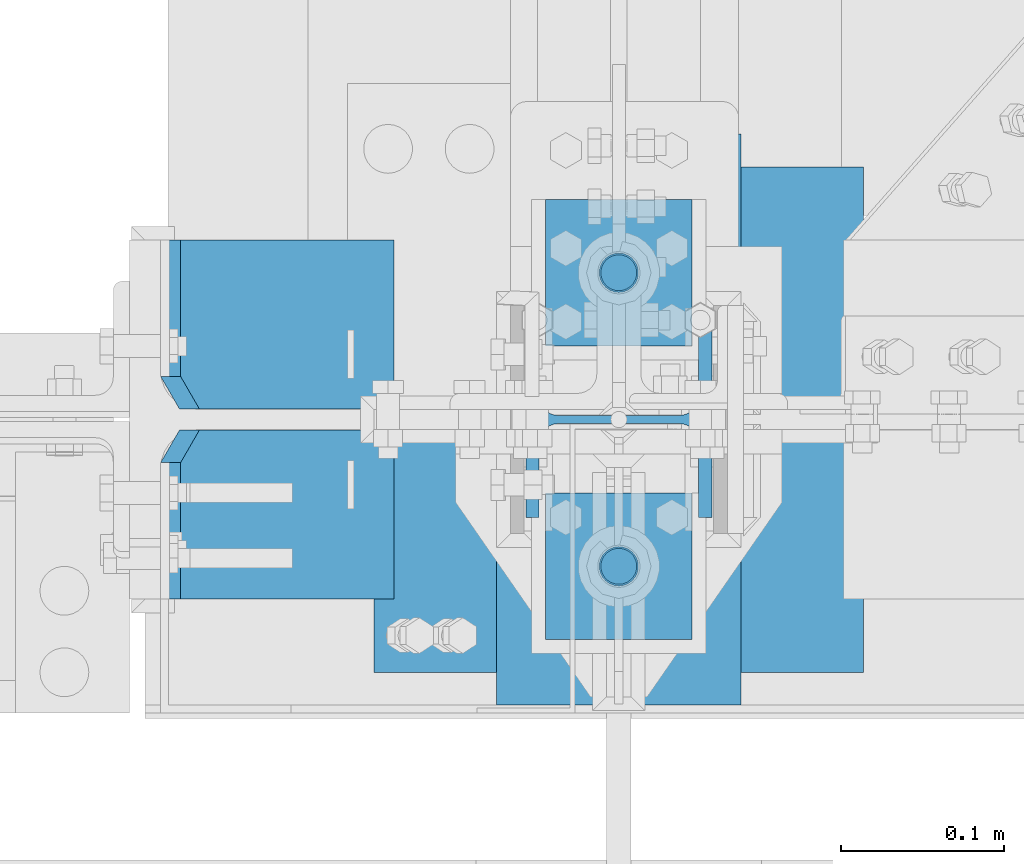
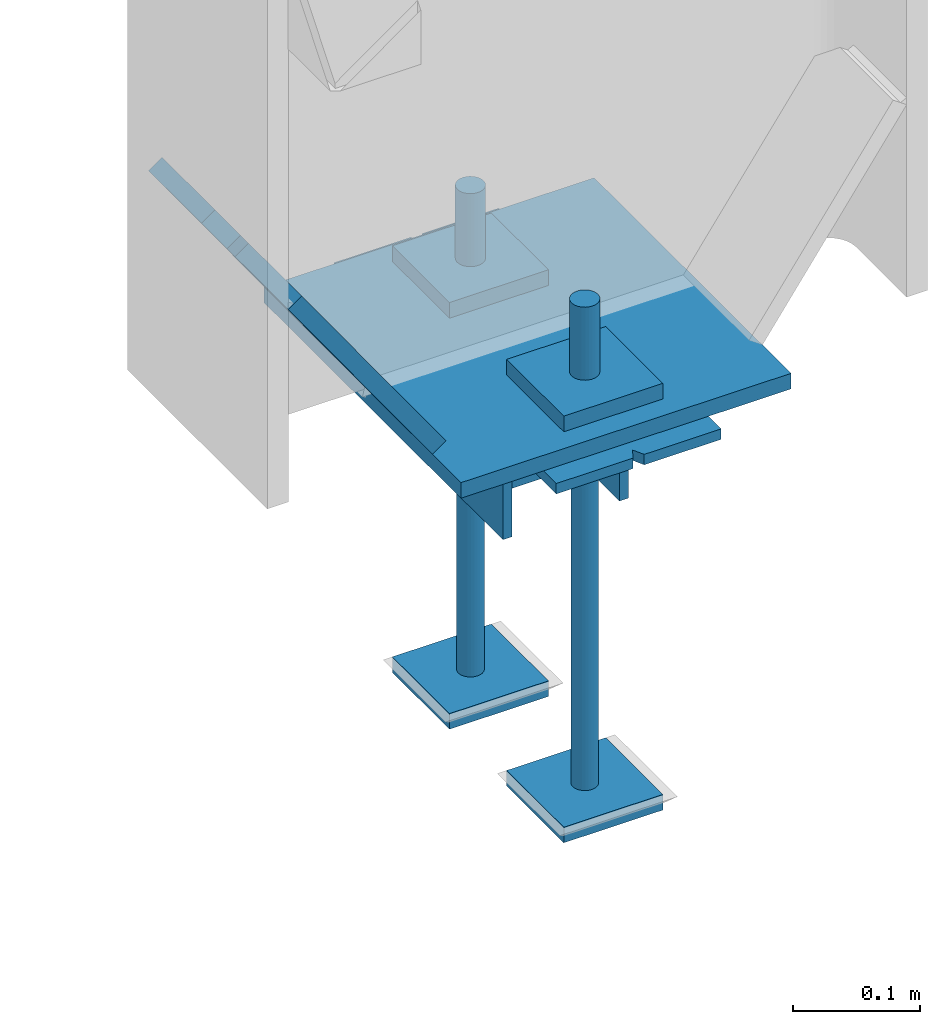
# One storey, part 69 of 496: 11 beams, 2 members, 2 elements without a shape of their own.
"""IFC2X3 building model written with IfcOpenShell, lengths in millimetres."""

from ifc_helpers import new_model, si_unit, frame, origin_with_axes, origin_2d_with_axis, place, context, subcontext, project, spatial, polyline, rectangle, circle, i_section, outline, extrude, boolean, material, type_object, element, aggregate, save


model = new_model("IFC2X3")

# Units and contexts
model_context = context("Model", 3, precision=1e-05, world=origin_with_axes())
body_context = subcontext(model_context, "Body", "Model", "MODEL_VIEW")
ifc_project = project(units=[si_unit("LENGTHUNIT", "METRE", prefix="MILLI"), si_unit("AREAUNIT", "SQUARE_METRE"), si_unit("VOLUMEUNIT", "CUBIC_METRE"), si_unit("MASSUNIT", "GRAM", prefix="KILO"), si_unit("TIMEUNIT", "SECOND"), si_unit("PLANEANGLEUNIT", "RADIAN"), si_unit("SOLIDANGLEUNIT", "STERADIAN"), si_unit("THERMODYNAMICTEMPERATUREUNIT", "DEGREE_CELSIUS"), si_unit("LUMINOUSINTENSITYUNIT", "LUMEN")], contexts=[model_context])

# Site, building, storey
site_placement = place(None, origin_with_axes())
site = spatial("IfcSite", under=ifc_project, at=site_placement, CompositionType="ELEMENT")
building_placement = place(site_placement, origin_with_axes())
building = spatial("IfcBuilding", under=site, at=building_placement, Name="Undefined", CompositionType="ELEMENT")
storey_placement = place(building_placement, origin_with_axes())
storey = spatial("IfcBuildingStorey", under=building, at=storey_placement, Name="Undefined", CompositionType="ELEMENT", Elevation=0.0)

# Assembly, beams
assembly_1_placement = place(storey_placement, origin_with_axes())
assembly_1 = element("IfcElementAssembly", 1, at=assembly_1_placement, inside=storey, Name="PS24", AssemblyPlace="NOTDEFINED", PredefinedType="NOTDEFINED")
ifc_material_1 = material(Name="Undefined/S235-E24")
beam_type_1 = type_object("IfcBeamType", PredefinedType="NOTDEFINED")
beam_1_placement = place(assembly_1_placement, frame((12725.0, -45.0028495552906, -177.5), z_axis=(0.0, 0.0, 1.0), x_axis=(-1.0, 0.0, 0.0)))
beam_1 = element("IfcBeam", 2, at=beam_1_placement, type_object=beam_type_1, material=ifc_material_1, context=body_context, shape_type="SweptSolid", body=[
    extrude(outline(polyline([(0.0, 0.0), (90.0, 0.0), (90.0, 90.0), (0.0, 90.0), (0.0, 0.0)])), frame((0.0, 0.0, -7.5), z_axis=(0.0, 0.0, 1.0), x_axis=(1.0, 0.0, 0.0)), (0.0, 0.0, 1.0), 15.0),
])
beam_2_placement = place(assembly_1_placement, frame((12725.0, 134.997150444709, -177.5), z_axis=(0.0, 0.0, 1.0), x_axis=(-1.0, 0.0, 0.0)))
beam_2 = element("IfcBeam", 3, at=beam_2_placement, type_object=beam_type_1, material=ifc_material_1, context=body_context, shape_type="SweptSolid", body=[
    extrude(outline(polyline([(0.0, 0.0), (90.0, 0.0), (90.0, 90.0), (0.0, 90.0), (0.0, 0.0)])), frame((0.0, 0.0, -7.5), z_axis=(0.0, 0.0, 1.0), x_axis=(1.0, 0.0, 0.0)), (0.0, 0.0, 1.0), 15.0),
])
beam_3_placement = place(assembly_1_placement, frame((12725.0, -45.0028495552906, -572.5), z_axis=(0.0, 0.0, 1.0), x_axis=(-1.0, 0.0, 0.0)))
beam_3 = element("IfcBeam", 4, at=beam_3_placement, type_object=beam_type_1, material=ifc_material_1, context=body_context, shape_type="SweptSolid", body=[
    extrude(outline(polyline([(0.0, 0.0), (90.0, 0.0), (90.0, 90.0), (0.0, 90.0), (0.0, 0.0)])), frame((0.0, 0.0, -7.5), z_axis=(0.0, 0.0, 1.0), x_axis=(1.0, 0.0, 0.0)), (0.0, 0.0, 1.0), 15.0),
])
beam_4_placement = place(assembly_1_placement, frame((12725.0, 134.997150444709, -572.5), z_axis=(0.0, 0.0, 1.0), x_axis=(-1.0, 0.0, 0.0)))
beam_4 = element("IfcBeam", 5, at=beam_4_placement, type_object=beam_type_1, material=ifc_material_1, context=body_context, shape_type="SweptSolid", body=[
    extrude(outline(polyline([(0.0, 0.0), (90.0, 0.0), (90.0, 90.0), (0.0, 90.0), (0.0, 0.0)])), frame((0.0, 0.0, -7.5), z_axis=(0.0, 0.0, 1.0), x_axis=(1.0, 0.0, 0.0)), (0.0, 0.0, 1.0), 15.0),
])
beam_type_2 = type_object("IfcBeamType", Name="D24", PredefinedType="NOTDEFINED")
beam_5_placement = place(assembly_1_placement, frame((12680.0, -90.0028495552906, -100.0), z_axis=(-1.0, 0.0, 0.0), x_axis=(0.0, 0.0, -1.0)))
beam_5 = element("IfcBeam", 6, at=beam_5_placement, type_object=beam_type_2, material=ifc_material_1, ObjectType="D24", context=body_context, shape_type="SweptSolid", body=[
    extrude(circle(Radius=12.0, at=origin_2d_with_axis()), frame((149.999995982835, 4.54747350886464e-12, 3.63797880709171e-12), z_axis=(-1.0, 0.0, 0.0), x_axis=(0.0, -1.0, 0.0)), (0.0, 0.0, 1.0), 150.0),
])
beam_6_placement = place(assembly_1_placement, frame((12680.0, 89.9971504447094, -100.0), z_axis=(-1.0, 0.0, 0.0), x_axis=(0.0, 0.0, -1.0)))
beam_6 = element("IfcBeam", 7, at=beam_6_placement, type_object=beam_type_2, material=ifc_material_1, ObjectType="D24", context=body_context, shape_type="SweptSolid", body=[
    extrude(circle(Radius=12.0, at=origin_2d_with_axis()), frame((149.999995982835, 4.54747350886464e-12, 3.63797880709171e-12), z_axis=(-1.0, 0.0, 0.0), x_axis=(0.0, -1.0, 0.0)), (0.0, 0.0, 1.0), 150.0),
])
beam_type_3 = type_object("IfcBeamType", Name="D22", PredefinedType="NOTDEFINED")
beam_7_placement = place(assembly_1_placement, frame((12680.0, -90.0028495552906, -250.0), z_axis=(-1.0, 0.0, 0.0), x_axis=(0.0, 0.0, -1.0)))
beam_7 = element("IfcBeam", 8, at=beam_7_placement, type_object=beam_type_3, material=ifc_material_1, ObjectType="D22", context=body_context, shape_type="SweptSolid", body=[
    extrude(circle(Radius=11.0, at=origin_2d_with_axis()), frame((350.0, 0.0, 0.0), z_axis=(-1.0, 0.0, 0.0), x_axis=(0.0, -1.0, 0.0)), (0.0, 0.0, 1.0), 350.0),
])
beam_8_placement = place(assembly_1_placement, frame((12680.0, 89.9971504447094, -250.0), z_axis=(-1.0, 0.0, 0.0), x_axis=(0.0, 0.0, -1.0)))
beam_8 = element("IfcBeam", 9, at=beam_8_placement, type_object=beam_type_3, material=ifc_material_1, ObjectType="D22", context=body_context, shape_type="SweptSolid", body=[
    extrude(circle(Radius=11.0, at=origin_2d_with_axis()), frame((350.0, 0.0, 0.0), z_axis=(-1.0, 0.0, 0.0), x_axis=(0.0, -1.0, 0.0)), (0.0, 0.0, 1.0), 350.0),
])
beam_type_4 = type_object("IfcBeamType", PredefinedType="NOTDEFINED")
beam_9_placement = place(assembly_1_placement, frame((12680.0, 175.0, -205.0), z_axis=(1.0, 0.0, 0.0), x_axis=(0.0, -1.0, 0.0)))
beam_9 = element("IfcBeam", 10, at=beam_9_placement, type_object=beam_type_4, material=ifc_material_1, Name="PS24", context=body_context, shape_type="CSG", body=[
    boolean("DIFFERENCE", boolean("DIFFERENCE", boolean("DIFFERENCE", boolean("DIFFERENCE", extrude(rectangle(XDim=10.0, YDim=150.0, at=origin_2d_with_axis()), frame((350.0, 0.0, 0.0), z_axis=(-1.0, 0.0, 0.0), x_axis=(0.0, -1.0, 0.0)), (0.0, 0.0, 1.0), 350.0), extrude(outline(polyline([(0.0, 0.0), (11.1803398132297, 1.2732925824821e-11), (4.47213602066586, 8.94427204135718), (0.0, 0.0)])), frame((0.0, 7.5, -5.0), z_axis=(0.0, -1.0, 0.0), x_axis=(0.894427191199935, 0.0, 0.44721359509992)), (0.0, 0.0, 1.0), 15.0)), extrude(outline(polyline([(0.0, 0.0), (11.1803398132297, 1.2732925824821e-11), (4.47213602066586, 8.94427204135718), (0.0, 0.0)])), frame((180.0, 7.5, -75.0), z_axis=(0.0, -1.0, 0.0), x_axis=(-0.447213595099959, 0.0, 0.894427191199915)), (0.0, 0.0, 1.0), 15.0)), extrude(outline(polyline([(0.0, 0.0), (11.1803398132297, 1.2732925824821e-11), (6.70820379256475, 8.94427204134627), (0.0, 0.0)])), frame((340.0, 7.5, 0.0), z_axis=(0.0, -1.0, 0.0), x_axis=(0.894427191199935, 0.0, -0.44721359509992)), (0.0, 0.0, 1.0), 15.0)), extrude(outline(polyline([(0.0, 0.0), (11.1803398132297, 1.2732925824821e-11), (4.47213602066586, 8.94427204135718), (0.0, 0.0)])), frame((170.0, 7.5, 75.0), z_axis=(0.0, -1.0, 0.0), x_axis=(0.447213595099959, 0.0, -0.894427191199915)), (0.0, 0.0, 1.0), 15.0)),
])
ifc_material_2 = material(Name="Undefined/S275-E28")
beam_type_5 = type_object("IfcBeamType", Name="HEA120", PredefinedType="NOTDEFINED")
beam_10_placement = place(assembly_1_placement, frame((12679.99999991, 0.0, -210.0), z_axis=(-1.0, 0.0, 0.0), x_axis=(0.0, 0.0, -1.0)))
beam_10 = element("IfcBeam", 11, at=beam_10_placement, type_object=beam_type_5, material=ifc_material_2, ObjectType="HEA120", context=body_context, shape_type="SweptSolid", body=[
    extrude(i_section(OverallWidth=120.0, OverallDepth=114.0, WebThickness=5.0, FlangeThickness=8.0, FilletRadius=12.0, at=origin_2d_with_axis()), frame((120.0, 0.0, 0.0), z_axis=(-1.0, 0.0, 0.0), x_axis=(0.0, -1.0, 0.0)), (0.0, 0.0, 1.0), 120.0),
])
aggregate(assembly_1, [beam_10, beam_1, beam_2, beam_3, beam_4, beam_5, beam_7, beam_6, beam_8, beam_9])

# Assembly, members, beam
assembly_2_placement = place(storey_placement, origin_with_axes())
assembly_2 = element("IfcElementAssembly", 12, at=assembly_2_placement, inside=storey, Name="POTEAU", AssemblyPlace="NOTDEFINED", PredefinedType="NOTDEFINED")
member_type = type_object("IfcMemberType", PredefinedType="NOTDEFINED")
member_1_placement = place(assembly_2_placement, frame((12405.1180011955, 58.25, 4.33427348522009), z_axis=(0.0, 1.0, 0.0), x_axis=(0.57790313132773, 0.0, -0.816105367462807)))
member_1 = element("IfcMember", 13, at=member_1_placement, type_object=member_type, material=ifc_material_1, context=body_context, shape_type="CSG", body=[
    boolean("DIFFERENCE", extrude(rectangle(XDim=15.0, YDim=103.5, at=origin_2d_with_axis()), frame((226.686414991487, 0.0, 0.0), z_axis=(-1.0, 0.0, 0.0), x_axis=(0.0, -1.0, 0.0)), (0.0, 0.0, 1.0), 226.69), extrude(outline(polyline([(0.0, 0.0), (20.0, 0.0), (20.0000000083892, 20.0), (0.0, 0.0)])), frame((20.0000000094935, -10.4999999943284, -51.75), z_axis=(0.0, 1.0, 0.0), x_axis=(-1.0, 0.0, 0.0)), (0.0, 0.0, 1.0), 21.0)),
])
member_2_placement = place(assembly_2_placement, frame((12405.1180011955, -58.25, 4.33427348522009), z_axis=(0.0, 1.0, 0.0), x_axis=(0.57790313132773, 0.0, -0.816105367462807)))
member_2 = element("IfcMember", 14, at=member_2_placement, type_object=member_type, material=ifc_material_1, context=body_context, shape_type="CSG", body=[
    boolean("DIFFERENCE", extrude(rectangle(XDim=15.0, YDim=103.5, at=origin_2d_with_axis()), frame((226.686414991487, 0.0, 0.0), z_axis=(-1.0, 0.0, 0.0), x_axis=(0.0, -1.0, 0.0)), (0.0, 0.0, 1.0), 226.69), extrude(outline(polyline([(0.0, 0.0), (28.2842712384918, -5.68070390727371e-09), (14.1421356183728, 14.1421356144456), (0.0, 0.0)])), frame((19.9999999913595, -10.4999999943284, 51.7500000027402), z_axis=(0.0, 1.0, 0.0), x_axis=(-0.707106781368632, 1.08068498594349e-10, -0.707106781004463)), (0.0, 0.0, 1.0), 21.0)),
])
beam_type_6 = type_object("IfcBeamType", PredefinedType="NOTDEFINED")
beam_11_placement = place(assembly_2_placement, frame((12680.0, 154.997150444709, -192.5), z_axis=(1.0, 0.0, 0.0), x_axis=(0.0, -1.0, 0.0)))
beam_11 = element("IfcBeam", 15, at=beam_11_placement, type_object=beam_type_6, material=ifc_material_1, context=body_context, shape_type="SweptSolid", body=[
    extrude(rectangle(XDim=15.0, YDim=300.0, at=origin_2d_with_axis()), frame((310.0, 0.0, 0.0), z_axis=(-1.0, 0.0, 0.0), x_axis=(0.0, -1.0, 0.0)), (0.0, 0.0, 1.0), 310.0),
])
aggregate(assembly_2, [member_1, member_2, beam_11])

save(model, "model.ifc")
